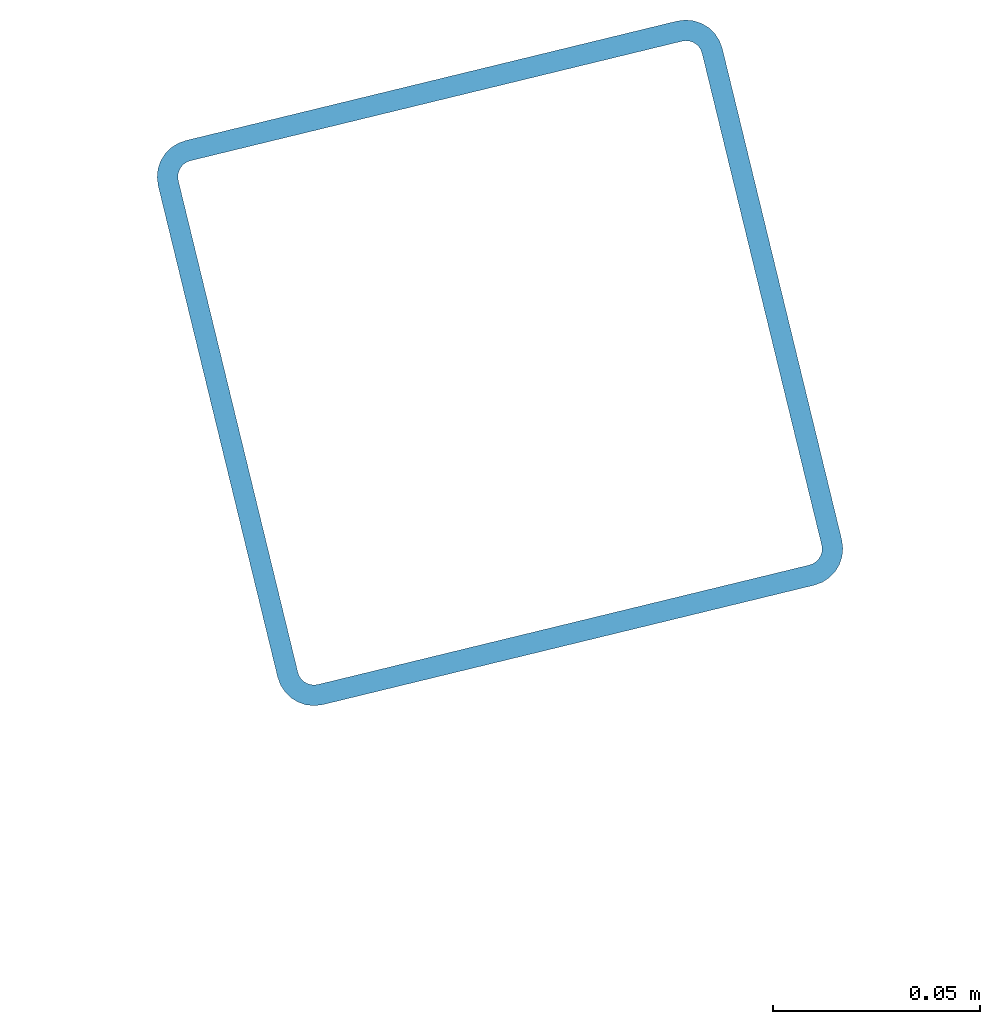
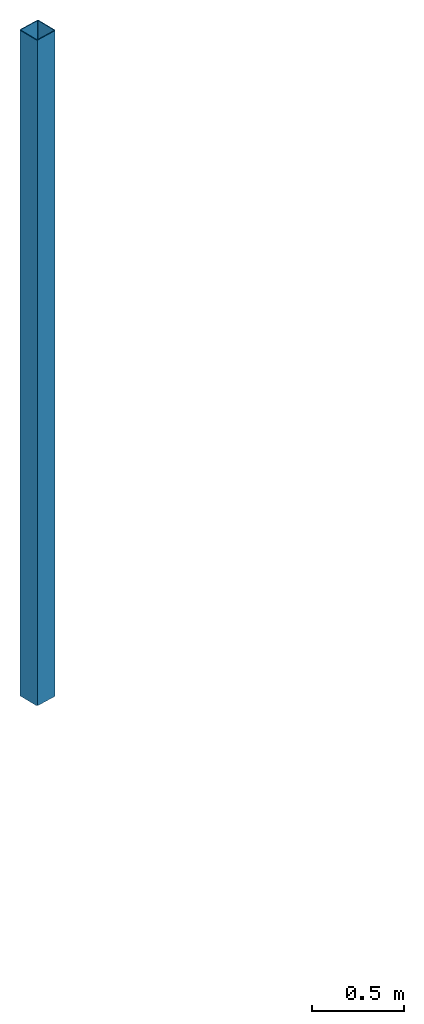
# One storey, part 6 of 10: 1 beam.
"""IFC2X3 building model written with IfcOpenShell, lengths in millimetres."""

from ifc_helpers import new_model, entity, si_unit, converted_unit, derived_unit, direction, frame, frame_2d, origin, place, context, subcontext, project, spatial, polyline, circle_curve, parameter, trimmed, segment, composite_curve, outline, extrude, material, type_object, element, save


model = new_model("IFC2X3")

# Units and contexts
model_context = context("Model", 3, precision=0.01, world=origin(), true_north=direction((6.12303176911189e-17, 1.0)))
body_context = subcontext(model_context, "Body", "Model", "MODEL_VIEW")
ifc_project = project(units=[si_unit("LENGTHUNIT", "METRE", prefix="MILLI"), si_unit("AREAUNIT", "SQUARE_METRE"), si_unit("VOLUMEUNIT", "CUBIC_METRE"), converted_unit("PLANEANGLEUNIT", "DEGREE", entity("IfcRatioMeasure", 0.0174532925199433), si_unit("PLANEANGLEUNIT", "RADIAN"), dimensions=[0, 0, 0, 0, 0, 0, 0]), si_unit("MASSUNIT", "GRAM", prefix="KILO"), derived_unit("MASSDENSITYUNIT", [(si_unit("MASSUNIT", "GRAM", prefix="KILO"), 1), (si_unit("LENGTHUNIT", "METRE"), -3)]), derived_unit("MOMENTOFINERTIAUNIT", [(si_unit("LENGTHUNIT", "METRE"), 4)]), si_unit("TIMEUNIT", "SECOND"), si_unit("FREQUENCYUNIT", "HERTZ"), si_unit("THERMODYNAMICTEMPERATUREUNIT", "DEGREE_CELSIUS"), derived_unit("THERMALTRANSMITTANCEUNIT", [(si_unit("MASSUNIT", "GRAM", prefix="KILO"), 1), (si_unit("THERMODYNAMICTEMPERATUREUNIT", "KELVIN"), -1), (si_unit("TIMEUNIT", "SECOND"), -3)]), derived_unit("VOLUMETRICFLOWRATEUNIT", [(si_unit("LENGTHUNIT", "METRE"), 3), (si_unit("TIMEUNIT", "SECOND"), -1)]), derived_unit("MASSFLOWRATEUNIT", [(si_unit("MASSUNIT", "GRAM", prefix="KILO"), 1), (si_unit("TIMEUNIT", "SECOND"), -1)]), derived_unit("ROTATIONALFREQUENCYUNIT", [(si_unit("TIMEUNIT", "SECOND"), -1)]), si_unit("ELECTRICCURRENTUNIT", "AMPERE"), si_unit("ELECTRICVOLTAGEUNIT", "VOLT"), si_unit("POWERUNIT", "WATT"), si_unit("FORCEUNIT", "NEWTON", prefix="KILO"), si_unit("ILLUMINANCEUNIT", "LUX"), si_unit("LUMINOUSFLUXUNIT", "LUMEN"), si_unit("LUMINOUSINTENSITYUNIT", "CANDELA"), derived_unit("USERDEFINED", [(si_unit("MASSUNIT", "GRAM", prefix="KILO"), -1), (si_unit("LENGTHUNIT", "METRE"), -2), (si_unit("TIMEUNIT", "SECOND"), 3), (si_unit("LUMINOUSFLUXUNIT", "LUMEN"), 1)]), derived_unit("LINEARVELOCITYUNIT", [(si_unit("LENGTHUNIT", "METRE"), 1), (si_unit("TIMEUNIT", "SECOND"), -1)]), si_unit("PRESSUREUNIT", "PASCAL"), derived_unit("USERDEFINED", [(si_unit("LENGTHUNIT", "METRE"), -2), (si_unit("MASSUNIT", "GRAM", prefix="KILO"), 1), (si_unit("TIMEUNIT", "SECOND"), -2)]), derived_unit("LINEARFORCEUNIT", [(si_unit("MASSUNIT", "GRAM", prefix="KILO"), 1), (si_unit("LENGTHUNIT", "METRE"), 1), (si_unit("TIMEUNIT", "SECOND"), -2), (si_unit("LENGTHUNIT", "METRE"), -1)]), derived_unit("PLANARFORCEUNIT", [(si_unit("MASSUNIT", "GRAM", prefix="KILO"), 1), (si_unit("LENGTHUNIT", "METRE"), 1), (si_unit("TIMEUNIT", "SECOND"), -2), (si_unit("LENGTHUNIT", "METRE"), -2)])], contexts=[model_context])

# Site, building, storey
site_placement = place(None, frame((19171.746869958, -72498.5768491146, 0.0), z_axis=(0.0, 0.0, 1.0), x_axis=(0.971695960795463, 0.236234967296933, 0.0)))
site = spatial("IfcSite", under=ifc_project, at=site_placement, CompositionType="ELEMENT")
building_placement = place(site_placement, origin())
building = spatial("IfcBuilding", under=site, at=building_placement, CompositionType="ELEMENT")
storey_placement = place(building_placement, origin())
storey = spatial("IfcBuildingStorey", under=building, at=storey_placement, CompositionType="ELEMENT", Elevation=0.0)

# Beam
ifc_material = material()
beam_type = type_object("IfcBeamType", PredefinedType="NOTDEFINED")
beam_placement = place(storey_placement, frame((11328.4047277641, 20028.4047277641, -180.0), z_axis=(1.0, 0.0, 0.0), x_axis=(0.0, 0.0, -1.0)))
element("IfcBeam", 1, at=beam_placement, inside=storey, type_object=beam_type, material=ifc_material, context=body_context, shape_type="SweptSolid", body=[
    extrude(outline(composite_curve([segment(trimmed(circle_curve(frame_2d((61.0, -61.0), x_axis=(1.0, 0.0)), 8.99999999999772), [parameter(269.999999999999)], [parameter(1.27222187258541e-12)], True, "PARAMETER"), True, "CONTINUOUS"), segment(polyline([(70.0, -61.0), (70.0, 61.0)]), True, "CONTINUOUS"), segment(trimmed(circle_curve(frame_2d((61.0, 61.0), x_axis=(1.0, 0.0)), 8.99999999999909), [parameter(1.27222187258541e-12)], [parameter(90.0000000000001)], True, "PARAMETER"), True, "CONTINUOUS"), segment(polyline([(61.0, 70.0), (-61.0, 70.0)]), True, "CONTINUOUS"), segment(trimmed(circle_curve(frame_2d((-61.0, 61.0), x_axis=(1.0, 0.0)), 8.99999999999999), [parameter(90.0000000000001)], [parameter(180.0)], True, "PARAMETER"), True, "CONTINUOUS"), segment(polyline([(-70.0, 61.0), (-70.0, -61.0)]), True, "CONTINUOUS"), segment(trimmed(circle_curve(frame_2d((-61.0, -61.0), x_axis=(1.0, 0.0)), 8.99999999999937), [parameter(180.0)], [parameter(269.999999999998)], True, "PARAMETER"), True, "CONTINUOUS"), segment(polyline([(-61.0, -70.0), (61.0, -70.0)]), True, "CONTINUOUS")], self_intersect=False), holes=[composite_curve([segment(polyline([(61.0, -65.0), (-61.0, -65.0)]), True, "CONTINUOUS"), segment(trimmed(circle_curve(frame_2d((-61.0, -61.0), x_axis=(1.0, 0.0)), 3.99999999999972), [parameter(180.0)], [parameter(270.0)], True, "PARAMETER"), False, "CONTINUOUS"), segment(polyline([(-65.0, -61.0), (-65.0, 61.0)]), True, "CONTINUOUS"), segment(trimmed(circle_curve(frame_2d((-61.0, 61.0), x_axis=(1.0, 0.0)), 3.99999999999971), [parameter(90.0000000000003)], [parameter(180.0)], True, "PARAMETER"), False, "CONTINUOUS"), segment(polyline([(-61.0, 65.0), (61.0, 65.0)]), True, "CONTINUOUS"), segment(trimmed(circle_curve(frame_2d((61.0, 61.0), x_axis=(1.0, 0.0)), 3.9999999999997), [parameter(3.56222124323914e-13)], [parameter(90.0000000000004)], True, "PARAMETER"), False, "CONTINUOUS"), segment(polyline([(65.0, 61.0), (65.0, -61.0)]), True, "CONTINUOUS"), segment(trimmed(circle_curve(frame_2d((61.0, -61.0), x_axis=(1.0, 0.0)), 4.00000000000034), [parameter(270.0)], [parameter(5.08888749034163e-13)], True, "PARAMETER"), False, "CONTINUOUS")], self_intersect=False)]), frame((-4419.5405845398, 71.5952722359182, 71.5952722359185), z_axis=(1.0, 0.0, 0.0), x_axis=(0.0, 0.0, 1.0)), (0.0, 0.0, 1.0), 4419.5405845398),
])

save(model, "model.ifc")
